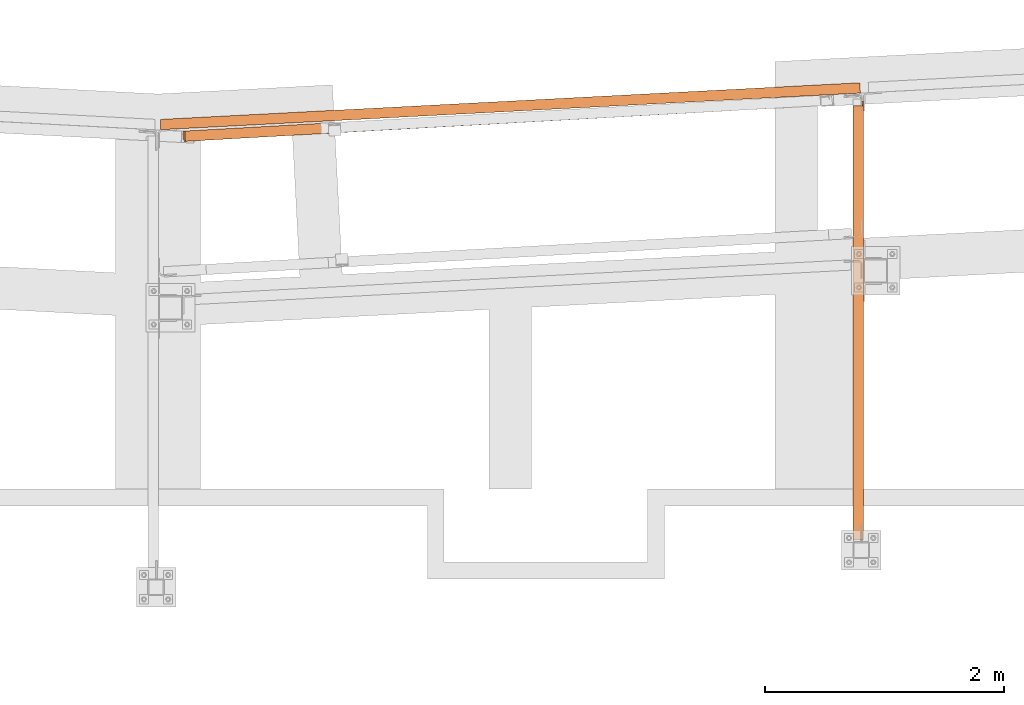
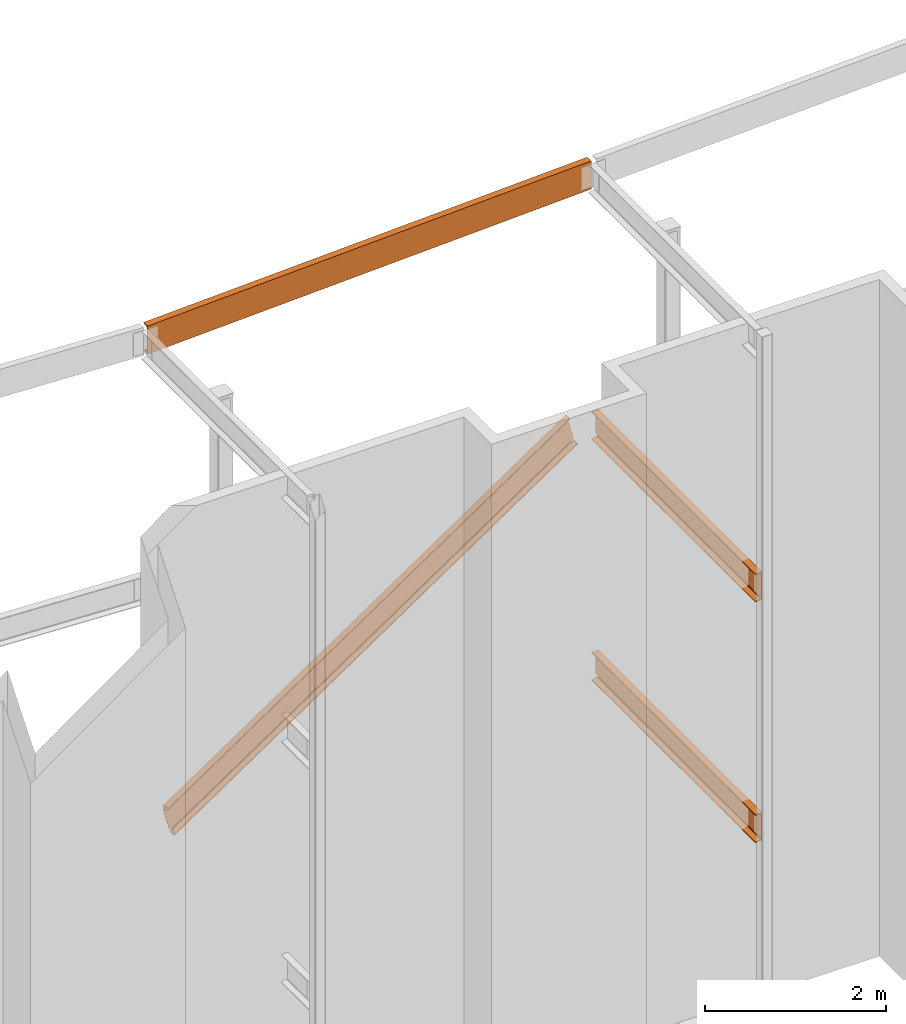
# One storey, part 16 of 89: 4 proxies.
"""IFC4 building model written with IfcOpenShell, lengths in feet."""

import ifcopenshell
import ifcopenshell.guid

model = None  # the IFC model being written
_history = None  # IfcOwnerHistory: only IFC2X3 demands one
_inside = {}  # id of a spatial element -> (the spatial element, [elements in it])
_under = {}  # id of a project, library or spatial element -> (it, [spatial elements below it])
_declared = {}  # id of a project -> (the project, [libraries it declares])
_typed = {}  # id of a type object -> (the type object, [elements of that type])
_made_of = {}  # id of a material, layer set ... -> (it, [elements and type objects made of it])


def new_model(schema):
    """Start an empty IFC model of exactly this schema.

    Asked for "IFC4X3", IfcOpenShell would pick the latest addendum, in which some entities
    have other attributes; the version numbers below select the first issue.
    IFC2X3 requires an IfcOwnerHistory on every rooted entity: one is made here for all.
    """
    global model, _history
    if schema == "IFC4X3":
        model = ifcopenshell.file(schema_version=(4, 3, 0, 0))
    else:
        model = ifcopenshell.file(schema=schema)
    _inside.clear()
    _under.clear()
    _declared.clear()
    _typed.clear()
    _made_of.clear()
    _history = None
    if model.schema == "IFC2X3":
        org = make("IfcOrganization", Name="unknown")
        user = make(
            "IfcPersonAndOrganization",
            ThePerson=make("IfcPerson", FamilyName="unknown"),
            TheOrganization=org,
        )
        app = make(
            "IfcApplication",
            ApplicationDeveloper=org,
            Version="unknown",
            ApplicationFullName="unknown",
            ApplicationIdentifier="unknown",
        )
        _history = make(
            "IfcOwnerHistory",
            OwningUser=user,
            OwningApplication=app,
            ChangeAction="ADDED",
            CreationDate=0,
        )
    return model


def make(cls, **values):
    """One entity of the class cls with the attributes given. An attribute that is None is left unset."""
    return model.create_entity(
        cls, **{name: value for name, value in values.items() if value is not None}
    )


def entity(cls, *values):
    """Any entity or typed value of the class cls, its attributes in the order of the schema. None: left unset."""
    e = model.create_entity(cls)
    for i, value in enumerate(values):
        if value is not None:
            e[i] = value
    return e


def rooted(cls, **values):
    """An entity with a GlobalId (a new one), such as an element, a storey or a relation."""
    return make(cls, GlobalId=ifcopenshell.guid.new(), OwnerHistory=_history, **values)


def si_unit(unit_type, name, prefix=None):
    """IfcSIUnit, for example si_unit("LENGTHUNIT", "METRE", prefix="MILLI")."""
    return make("IfcSIUnit", UnitType=unit_type, Prefix=prefix, Name=name)


def converted_unit(unit_type, name, factor, base, dimensions=None, offset=None):
    """IfcConversionBasedUnit, such as the inch: factor (a typed value) times the base unit."""
    return make(
        "IfcConversionBasedUnit"
        if offset is None
        else "IfcConversionBasedUnitWithOffset",
        ConversionOffset=offset,
        Dimensions=None
        if dimensions is None
        else entity("IfcDimensionalExponents", *dimensions),
        UnitType=unit_type,
        Name=name,
        ConversionFactor=make(
            "IfcMeasureWithUnit", ValueComponent=factor, UnitComponent=base
        ),
    )


def derived_unit(unit_type, elements):
    """IfcDerivedUnit: a product of units, each with its exponent."""
    return make(
        "IfcDerivedUnit",
        Elements=[
            make("IfcDerivedUnitElement", Unit=unit, Exponent=power)
            for unit, power in elements
        ],
        UnitType=unit_type,
    )


def assignment(units):
    """IfcUnitAssignment: the units of a project."""
    return None if units is None else make("IfcUnitAssignment", Units=units)


def point(xyz):
    """IfcCartesianPoint."""
    return None if xyz is None else make("IfcCartesianPoint", Coordinates=xyz)


def direction(xyz):
    """IfcDirection."""
    return None if xyz is None else make("IfcDirection", DirectionRatios=xyz)


def frame(location, z_axis=None, x_axis=None):
    """IfcAxis2Placement3D, a coordinate frame: its origin and axes. An axis left out is left unset."""
    return make(
        "IfcAxis2Placement3D",
        Location=point(location),
        Axis=direction(z_axis),
        RefDirection=direction(x_axis),
    )


def origin():
    """The frame at (0, 0, 0) with its axes left unset."""
    return frame((0.0, 0.0, 0.0))


def place(relative_to, where):
    """IfcLocalPlacement: puts the frame where relative to a parent placement (None: the world)."""
    return make(
        "IfcLocalPlacement", PlacementRelTo=relative_to, RelativePlacement=where
    )


def context(
    kind, dimensions, precision=None, world=None, true_north=None, identifier=None
):
    """IfcGeometricRepresentationContext, for example the 3D "Model" context."""
    return make(
        "IfcGeometricRepresentationContext",
        ContextIdentifier=identifier,
        ContextType=kind,
        CoordinateSpaceDimension=dimensions,
        Precision=precision,
        WorldCoordinateSystem=world,
        TrueNorth=true_north,
    )


def subcontext(parent, identifier, kind, view, scale=None):
    """IfcGeometricRepresentationSubContext, for example "Body" below "Model"."""
    return make(
        "IfcGeometricRepresentationSubContext",
        ContextIdentifier=identifier,
        ContextType=kind,
        ParentContext=parent,
        TargetScale=scale,
        TargetView=view,
    )


def project(units=None, contexts=None):
    """IfcProject with its units and contexts."""
    return rooted(
        "IfcProject",
        Name="project",
        RepresentationContexts=contexts,
        UnitsInContext=assignment(units),
    )


def spatial(cls, under=None, at=None, **own):
    """A site, building, storey or space (cls), placed at a placement, below another one or the project."""
    s = rooted(cls, ObjectPlacement=at, **own)
    if under is not None:
        _under.setdefault(under.id(), (under, []))[1].append(s)
    return s


def faces_of(points, faces, orient=None, outer=None):
    """IfcFace entities. A face is a list of loops; a loop is a list of indices into points, from 0.

    orient and outer hold one flag for each loop. By default every Orientation is true, the
    first loop of a face is its IfcFaceOuterBound and the others are IfcFaceBound.
    """
    made = []
    for i, loops in enumerate(faces):
        bounds = []
        for j, loop in enumerate(loops):
            is_outer = j == 0 if outer is None else outer[i][j]
            bounds.append(
                make(
                    "IfcFaceOuterBound" if is_outer else "IfcFaceBound",
                    Bound=make("IfcPolyLoop", Polygon=[points[k] for k in loop]),
                    Orientation=True if orient is None else orient[i][j],
                )
            )
        made.append(make("IfcFace", Bounds=bounds))
    return made


def face_set(faces, orient=None, outer=None):
    """The faces of one IfcConnectedFaceSet. surface_model builds it on its shared points."""
    return ("IfcConnectedFaceSet", faces, orient, outer)


def faceted_brep(points, faces, orient=None, outer=None, voids=None):
    """IfcFacetedBrep: a solid bounded by flat faces; with voids (closed shells), ...WithVoids."""
    shared = [point(p) for p in points]
    hull = make("IfcClosedShell", CfsFaces=faces_of(shared, faces, orient, outer))
    if voids is None:
        return make("IfcFacetedBrep", Outer=hull)
    return make(
        "IfcFacetedBrepWithVoids",
        Outer=hull,
        Voids=[
            make(cls, CfsFaces=faces_of(shared, fs, o, b)) for cls, fs, o, b in voids
        ],
    )


def surface_model(cls, points, shells):
    """IfcFaceBasedSurfaceModel or IfcShellBasedSurfaceModel (cls): surfaces that need not close."""
    shared = [point(p) for p in points]
    made = [make(c, CfsFaces=faces_of(shared, fs, o, b)) for c, fs, o, b in shells]
    if cls == "IfcFaceBasedSurfaceModel":
        return make(cls, FbsmFaces=made)
    return make(cls, SbsmBoundary=made)


def shape(context_of_items, identifier, shape_type, items):
    """IfcShapeRepresentation: the items that make up one representation, for example the "Body"."""
    return make(
        "IfcShapeRepresentation",
        ContextOfItems=context_of_items,
        RepresentationIdentifier=identifier,
        RepresentationType=shape_type,
        Items=items,
    )


def source(mapping_origin, context_of_items, identifier, shape_type, items):
    """IfcRepresentationMap: a shape defined once, which mapped items show again and again."""
    return make(
        "IfcRepresentationMap",
        MappingOrigin=mapping_origin,
        MappedRepresentation=shape(context_of_items, identifier, shape_type, items),
    )


def transform(
    local_origin,
    x_axis=None,
    y_axis=None,
    z_axis=None,
    scale=None,
    scale2=None,
    scale3=None,
    uniform=True,
):
    """IfcCartesianTransformationOperator3D, or its non-uniform kind. x_axis, y_axis, z_axis: its Axis1, 2, 3."""
    if uniform:
        return make(
            "IfcCartesianTransformationOperator3D",
            Axis1=direction(x_axis),
            Axis2=direction(y_axis),
            LocalOrigin=point(local_origin),
            Scale=scale,
            Axis3=direction(z_axis),
        )
    return make(
        "IfcCartesianTransformationOperator3DnonUniform",
        Axis1=direction(x_axis),
        Axis2=direction(y_axis),
        LocalOrigin=point(local_origin),
        Scale=scale,
        Axis3=direction(z_axis),
        Scale2=scale2,
        Scale3=scale3,
    )


def mapped(mapping_source, mapping_target):
    """IfcMappedItem: shows the shape of a source again, moved by a transform."""
    return make(
        "IfcMappedItem", MappingSource=mapping_source, MappingTarget=mapping_target
    )


def material(Name=None, Category=None):
    """IfcMaterial."""
    return make("IfcMaterial", Name=Name, Category=Category)


def constituent(of_material, Name=None, Category=None, fraction=None):
    """IfcMaterialConstituent: one of the materials an element consists of."""
    return make(
        "IfcMaterialConstituent",
        Name=Name,
        Material=of_material,
        Fraction=fraction,
        Category=Category,
    )


def constituent_set(constituents=None, Name=None):
    """IfcMaterialConstituentSet."""
    return make(
        "IfcMaterialConstituentSet", Name=Name, MaterialConstituents=constituents
    )


def made_of(thing, what):
    """Note that an element or type object is made of a material, layer set ...; save() writes the relation."""
    if what is not None:
        _made_of.setdefault(what.id(), (what, []))[1].append(thing)
    return thing


def type_object(cls, material=None, **own):
    """A type object (cls), such as IfcWallType, which elements share."""
    return made_of(rooted(cls, **own), material)


def type_shapes(of_type, sources):
    """Give a type object the sources (RepresentationMaps) that its elements show as mapped items."""
    of_type.RepresentationMaps = sources


def element(
    cls,
    number,
    at=None,
    inside=None,
    cuts=None,
    type_object=None,
    material=None,
    context=None,
    identifier="Body",
    shape_type=None,
    held_by="IfcProductDefinitionShape",
    body=None,
    shapes=None,
    **own,
):
    """One element of the class cls, such as IfcWall. Its Tag is "e" and its number.

    at: its placement. inside: the storey or other place that contains it. cuts: it is an
    opening in that element (IfcRelVoidsElement). A single representation is given by context,
    identifier, shape_type and body (its items); several are given by shapes. held_by: the class
    of the entity that holds the representations. save() writes the other relations.
    """
    e = rooted(cls, Tag="e%d" % number, ObjectPlacement=at, **own)
    if body is not None:
        shapes = [shape(context, identifier, shape_type, body)]
    if shapes is not None:
        e.Representation = make(held_by, Representations=shapes)
    if inside is not None:
        _inside.setdefault(inside.id(), (inside, []))[1].append(e)
    if cuts is not None:
        rooted(
            "IfcRelVoidsElement", RelatingBuildingElement=cuts, RelatedOpeningElement=e
        )
    if type_object is not None:
        _typed.setdefault(type_object.id(), (type_object, []))[1].append(e)
    return made_of(e, material)


def aggregate(whole, parts):
    """IfcRelAggregates: a whole, such as a stair, and the parts it consists of."""
    return rooted("IfcRelAggregates", RelatingObject=whole, RelatedObjects=parts)


def save(model, path):
    """Write the relations noted so far, then the file.

    IfcRelAggregates (storeys below a building ...), IfcRelContainedInSpatialStructure (elements
    in a storey), IfcRelDefinesByType, IfcRelAssociatesMaterial and IfcRelDeclares: one each for
    every whole, place, type object, material and project.
    """
    for whole, parts in _under.values():
        aggregate(whole, parts)
    for where, things in _inside.values():
        rooted(
            "IfcRelContainedInSpatialStructure",
            RelatedElements=things,
            RelatingStructure=where,
        )
    for kind, things in _typed.values():
        rooted("IfcRelDefinesByType", RelatedObjects=things, RelatingType=kind)
    for what, things in _made_of.values():
        rooted("IfcRelAssociatesMaterial", RelatedObjects=things, RelatingMaterial=what)
    for by, libraries in _declared.values():
        rooted("IfcRelDeclares", RelatingContext=by, RelatedDefinitions=libraries)
    model.write(path)


model = new_model("IFC4")

# Units and contexts
model_context = context("Model", 3, precision=0.0001, world=origin(), true_north=direction((6.12303176911189e-17, 1.0)))
body_context = subcontext(model_context, "Body", "Model", "MODEL_VIEW")
ifc_project = project(units=[converted_unit("LENGTHUNIT", "FOOT", entity("IfcRatioMeasure", 0.3048), si_unit("LENGTHUNIT", "METRE"), dimensions=[1, 0, 0, 0, 0, 0, 0]), converted_unit("AREAUNIT", "SQUARE FOOT", entity("IfcRatioMeasure", 0.09290304), si_unit("AREAUNIT", "SQUARE_METRE"), dimensions=[2, 0, 0, 0, 0, 0, 0]), converted_unit("VOLUMEUNIT", "CUBIC FOOT", entity("IfcRatioMeasure", 0.028316846592), si_unit("VOLUMEUNIT", "CUBIC_METRE"), dimensions=[3, 0, 0, 0, 0, 0, 0]), si_unit("PLANEANGLEUNIT", "RADIAN"), si_unit("MASSUNIT", "GRAM", prefix="KILO"), derived_unit("MASSDENSITYUNIT", [(si_unit("MASSUNIT", "GRAM", prefix="KILO"), 1), (si_unit("LENGTHUNIT", "METRE"), -3)]), derived_unit("MOMENTOFINERTIAUNIT", [(si_unit("LENGTHUNIT", "METRE"), 4)]), si_unit("TIMEUNIT", "SECOND"), si_unit("FREQUENCYUNIT", "HERTZ"), si_unit("THERMODYNAMICTEMPERATUREUNIT", "DEGREE_CELSIUS"), derived_unit("THERMALTRANSMITTANCEUNIT", [(si_unit("MASSUNIT", "GRAM", prefix="KILO"), 1), (si_unit("THERMODYNAMICTEMPERATUREUNIT", "KELVIN"), -1), (si_unit("TIMEUNIT", "SECOND"), -3)]), derived_unit("VOLUMETRICFLOWRATEUNIT", [(si_unit("LENGTHUNIT", "METRE"), 3), (si_unit("TIMEUNIT", "SECOND"), -1)]), si_unit("ELECTRICCURRENTUNIT", "AMPERE"), si_unit("ELECTRICVOLTAGEUNIT", "VOLT"), si_unit("POWERUNIT", "WATT"), si_unit("FORCEUNIT", "NEWTON"), si_unit("ILLUMINANCEUNIT", "LUX"), si_unit("LUMINOUSFLUXUNIT", "LUMEN"), si_unit("LUMINOUSINTENSITYUNIT", "CANDELA"), derived_unit("USERDEFINED", [(si_unit("MASSUNIT", "GRAM", prefix="KILO"), -1), (si_unit("LENGTHUNIT", "METRE"), -2), (si_unit("TIMEUNIT", "SECOND"), 3), (si_unit("LUMINOUSFLUXUNIT", "LUMEN"), 1)]), derived_unit("LINEARVELOCITYUNIT", [(si_unit("LENGTHUNIT", "METRE"), 1), (si_unit("TIMEUNIT", "SECOND"), -1)]), si_unit("PRESSUREUNIT", "PASCAL"), derived_unit("USERDEFINED", [(si_unit("LENGTHUNIT", "METRE"), -2), (si_unit("MASSUNIT", "GRAM", prefix="KILO"), 1), (si_unit("TIMEUNIT", "SECOND"), -2)]), derived_unit("LINEARFORCEUNIT", [(si_unit("MASSUNIT", "GRAM", prefix="KILO"), 1), (si_unit("LENGTHUNIT", "METRE"), 1), (si_unit("TIMEUNIT", "SECOND"), -2), (si_unit("LENGTHUNIT", "METRE"), -1)]), derived_unit("PLANARFORCEUNIT", [(si_unit("MASSUNIT", "GRAM", prefix="KILO"), 1), (si_unit("LENGTHUNIT", "METRE"), 1), (si_unit("TIMEUNIT", "SECOND"), -2), (si_unit("LENGTHUNIT", "METRE"), -2)])], contexts=[model_context])

# Site, building, storey
site_placement = place(None, origin())
site = spatial("IfcSite", under=ifc_project, at=site_placement, CompositionType="ELEMENT")
building_placement = place(site_placement, frame((-472.238160486, -49.138065117, 0.0)))
building = spatial("IfcBuilding", under=site, at=building_placement, CompositionType="ELEMENT")
storey_placement = place(building_placement, origin())
storey = spatial("IfcBuildingStorey", under=building, at=storey_placement, Name="Level 1", CompositionType="ELEMENT", Elevation=0.0)

# Proxies
ifc_material_1 = material(Name="Color 7720", Category="Materials")
ifc_material_2 = material()
ifc_constituent_1 = constituent(ifc_material_2)
ifc_constituent_2 = constituent(ifc_material_1, Name="Color 7720", Category="Materials")
ifc_constituent_set_1 = constituent_set(constituents=[ifc_constituent_1, ifc_constituent_2])
building_element_proxy_type_1 = type_object("IfcBuildingElementProxyType", Name="33B1", PredefinedType="NOTDEFINED", material=ifc_constituent_set_1)
shared_shape_1 = source(origin(), body_context, "Body", "Brep", [
    faceted_brep([(1.07356754597276e-08, 0.098822714376638, 0.0), (0.00517908973890258, 0.0, 0.0), (0.00517908973890258, 0.0, 1.25), (1.07356754597276e-08, 0.098822714376638, 1.25), (1.07356754597276e-08, 0.098822714376638, 1.18593784317541), (0.00112219925708246, 0.0774100818106263, 1.18236429742144), (0.00203400554855193, 0.060011781330104, 1.17618476966831), (0.00277876240696173, 0.0458009739160161, 1.16438573990163), (0.00326544140554574, 0.0365145854208322, 1.14840935276805), (0.00343455786415348, 0.0332876511583891, 1.13020833333333), (0.00343455786415348, 0.0332876511583891, 0.119791666666668), (0.00326544140554574, 0.0365145854208322, 0.101590647231948), (0.00277876240696173, 0.0458009739160161, 0.0856142600983674), (0.00203400554855193, 0.060011781330104, 0.0738152303316859), (0.00112219925708246, 0.0774100818106263, 0.0676357025785457), (1.07356754597276e-08, 0.098822714376638, 0.0640621568245869), (19.1876777550914, 1.00531215615104, 1.25), (19.1876777550914, 1.00531215615104, 0.0), (19.1728492341558, 1.28825719099814, 0.0), (19.1728492341558, 1.28825719099814, 0.0333340558078774), (19.1836208646095, 1.08272223796166, 0.0676357025785457), (19.184532670901, 1.06532393748114, 0.0738152303316859), (19.1852774277594, 1.05111313006694, 0.0856142600983674), (19.185764106758, 1.04182674157175, 0.101590647231948), (19.1859332232166, 1.03859980730942, 0.119791666666668), (19.1859332232166, 1.03859980730942, 1.13020833333333), (19.185764106758, 1.04182674157175, 1.14840935276805), (19.1852774277594, 1.05111313006694, 1.16438573990163), (19.184532670901, 1.06532393748114, 1.17618476966831), (19.1836208646095, 1.08272223796166, 1.18236429742144), (19.1728492341558, 1.28825719099814, 1.21666594419212), (19.1728492341558, 1.28825719099814, 1.25), (0.0, 0.283450740107469, 1.25), (0.0, 0.283450740107469, 1.21666594419212), (0.0, 0.283450740107469, 0.0333340558077744), (0.0, 0.283450740107469, 0.0)], [[[0, 1, 2, 3, 4, 5, 6, 7, 8, 9, 10, 11, 12, 13, 14, 15]], [[16, 17, 18, 19, 20, 21, 22, 23, 24, 25, 26, 27, 28, 29, 30, 31]], [[32, 31, 30, 33]], [[33, 30, 29, 5, 4]], [[28, 6, 5, 29]], [[27, 7, 6, 28]], [[26, 8, 7, 27]], [[25, 9, 8, 26]], [[24, 10, 9, 25]], [[23, 11, 10, 24]], [[22, 12, 11, 23]], [[21, 13, 12, 22]], [[20, 14, 13, 21]], [[15, 14, 20, 19, 34]], [[34, 19, 18, 35]], [[35, 18, 17, 1, 0]], [[16, 2, 1, 17]], [[3, 2, 16, 31, 32]], [[32, 33, 4, 3]], [[35, 0, 15, 34]]]),
])
type_shapes(building_element_proxy_type_1, [shared_shape_1])
proxy_1_placement = place(building_placement, frame((230.562436454417, 1017.85373831147, 29.8333333333333)))
element("IfcBuildingElementProxy", 1, at=proxy_1_placement, inside=storey, type_object=building_element_proxy_type_1, material=ifc_material_1, Name="33B1:33B1", ObjectType="33B1:33B1", PredefinedType="NOTDEFINED", context=body_context, shape_type="MappedRepresentation", body=[
    mapped(shared_shape_1, transform((0.0, 0.0, 0.0), scale=1.0)),
])
ifc_constituent_3 = constituent(ifc_material_2)
ifc_constituent_4 = constituent(ifc_material_1, Name="Color 7720", Category="Materials")
ifc_constituent_set_2 = constituent_set(constituents=[ifc_constituent_3, ifc_constituent_4])
building_element_proxy_type_2 = type_object("IfcBuildingElementProxyType", Name="34B1", PredefinedType="NOTDEFINED", material=ifc_constituent_set_2)
shared_shape_2 = source(origin(), body_context, "Body", "SurfaceModel", [
    surface_model("IfcFaceBasedSurfaceModel", [(0.303696853038161, 0.299216112058275, 0.0100472176130761), (0.306442138279095, 0.299370292556091, 0.0), (0.322329646931337, 0.0164827444974662, 0.0), (0.319584361690403, 0.0163285639996502, 0.0100472176130761), (0.272073491763877, 0.264054221976608, 0.132623272492586), (0.00186911866509831, 0.248879024818052, 1.12151947025676), (0.0, 0.282159912824909, 1.12151947025676), (0.27020437309892, 0.297335109983464, 0.132623272492586), (17.4853650013783, 1.26417163321889, 11.8555669009117), (17.4726841039552, 1.263459449636, 11.901976554102), (17.4885716126074, 0.980571901577378, 11.901976554102), (17.4955203771162, 0.980962157553677, 11.8765454083247), (17.4942175429467, 1.10654630421539, 11.8555669009117), (17.776936677922, 1.28054685922518, 10.7884704694103), (17.5067323048232, 1.26537166206663, 11.7773666671744), (17.5086014234882, 1.23209077405977, 11.7773666671744), (17.778805796587, 1.24726597121833, 10.7884704694103), (17.8263166665136, 0.999540313241368, 10.6658944145308), (17.8290619517545, 0.999694493739185, 10.6558471969177), (17.8131744431022, 1.28258204179781, 10.6558471969177), (17.8104291578614, 1.28242786129999, 10.6658944145308), (17.6723666156622, 1.27467400345142, 10.7309934061653), (17.474895242037, 1.26358363139866, 11.7521389479438), (17.459821718768, 1.26273707334758, 11.7445609823409), (17.4429832387451, 1.26179139193152, 11.7435994189647), (17.4271474337542, 1.26090202267312, 11.749412303753), (17.4149171323874, 1.26021514543129, 11.7610442105221), (17.4083025499831, 1.25984365776446, 11.7765832781736), (17.4083908825644, 1.2598486186921, 11.7934754509082), (17.4151676114774, 1.26022921281856, 11.8089442718168), (17.4275188897288, 1.26092288435495, 11.8204472311014), (17.464769696828, 1.26301496130975, 11.906505391597), (0.0468476088837519, 0.284790964623994, 1.30471443339433), (0.00187177189698673, 0.282265035136675, 1.22557497871247), (0.00461705713792071, 0.282419215634604, 1.2155277610994), (0.0629075018788114, 0.285692919095595, 1.25110496611269), (0.0783833740528621, 0.28656207383483, 1.25672973424961), (0.0948259067738491, 0.28748551808917, 1.25590122080313), (0.10965999990276, 0.28831862928314, 1.24874918103221), (0.12056245445757, 0.288930932094786, 1.23639371114838), (0.125825813763782, 0.289226532474117, 1.22076982765763), (0.124625771888049, 0.289159135814884, 1.20432442029601), (0.117150269949519, 0.288739297251709, 1.18963303940614), (0.104570062260109, 0.288032768597873, 1.17899653350172), (0.302041435885315, 0.299123140650636, 0.157850991723214), (0.317109281134407, 0.299969379813206, 0.165427437479559), (0.333941811413098, 0.300914727080226, 0.166392245455572), (0.349774260727429, 0.301803907877343, 0.160586944628864), (0.362006127742148, 0.30249087304901, 0.148965063556631), (0.368628311662121, 0.302862787631511, 0.133435512013145), (0.368553109771113, 0.302858564148664, 0.116549039962802), (0.361792874081857, 0.30247889631346, 0.10107927340897), (0.349457982501775, 0.301786145083952, 0.0895671425501767), (0.34867269002487, 0.301742041548437, 0.0891866722949395), (17.7665947779691, 1.27996603823419, 10.6909776304976), (17.7140338862532, 1.27701411748819, 10.6588878488301), (17.6985580769897, 1.27614496628212, 10.6532609229392), (17.6821147802179, 1.27522147911725, 10.6540876961211), (17.6672794271848, 1.27438829716459, 10.6612386750317), (17.6563756049599, 1.27377591754191, 10.6735938376469), (17.6511111246262, 1.27348025420349, 10.6892180567048), (17.6523105353809, 1.27354761541778, 10.705664189), (17.6597859795225, 1.27396745073497, 10.7203563591718), (17.8032083479337, 0.998242505635517, 10.679117618486), (0.343294426074522, 0.0176601668063086, 0.0517674321002595), (17.7229121871204, 1.11893012726944, 10.6588878488252), (17.7754450538782, 1.12238105083907, 10.6909776304927), (0.35752296592841, 0.144157054144671, 0.0891866722998671), (0.358336296157603, 0.143701927047346, 0.0895671425550901), (0.369519878000062, 0.164894505900747, 0.101079273413857), (0.373015288666721, 0.223406532036734, 0.116549039967648), (0.372901520314599, 0.225464310771144, 0.116952059026719), (17.6854225827148, 1.19776878319919, 10.6545884278252), (17.6867871674784, 1.19202654882383, 10.6540876961162), (17.706345873092, 1.13747813112627, 10.6532609229344), (17.6778158029995, 1.2147912033397, 10.6577841699171), (0.371956887407862, 0.242860889888789, 0.124202859305775), (17.6664119819453, 1.22840347705926, 10.6651356381964), (0.369642943040276, 0.256983668561588, 0.137087075520316), (0.371465868682861, 0.252338217314104, 0.133435512013126), (17.6701973721288, 1.22243236696454, 10.6612386750317), (17.6568340082527, 1.23717934620981, 10.6783183953159), (0.361660843404138, 0.265849165067721, 0.151241195530037), (0.364160594214155, 0.264129179532006, 0.148965063556741), (17.6585847174705, 1.23444121534328, 10.673593837647), (17.6536032510574, 1.24023435551442, 10.6977606415586), (0.345526940138512, 0.26817950887812, 0.162829665837245), (0.351694131266271, 0.267619349353708, 0.16058694462885), (17.6530496923214, 1.23896278050506, 10.6892180567048), (17.6616550981883, 1.2406865627122, 10.7203563591718), (17.6742357343281, 1.24139311542854, 10.7309934061653), (17.4767643607029, 1.23030274337407, 11.7521389479438), (17.461690837434, 1.2294561853231, 11.7445609823409), (17.444852357411, 1.22851050390693, 11.7435994189647), (17.4351493635061, 1.22796556511173, 11.7471611189038), (0.127071721903349, 0.255910643782499, 1.21222933323467), (0.126494890552067, 0.255878247824626, 1.204324420296), (0.119019388613566, 0.25545840926145, 1.18963303940614), (0.106439180924127, 0.254751880607614, 1.17899653350172), (0.303910554549248, 0.265842252662083, 0.15785099172321), (0.31897839979834, 0.266688491824539, 0.165427437479559), (0.335810930077031, 0.267633839091673, 0.166392245455572), (17.6541796540468, 1.24026672739501, 10.705664189), (17.4193792282523, 1.22384342917269, 11.7587504291711), (0.124203520126315, 0.252513105195362, 1.23167168136501), (0.127764362625328, 0.254709394121505, 1.2207698276576), (17.4290674610728, 1.22671467258158, 11.749412303753), (17.4124401894706, 1.21413993284148, 11.7729046647747), (0.115668448404932, 0.242719972585292, 1.24485445737068), (0.122771476830565, 0.249597834855422, 1.23639371114834), (17.4170723659125, 1.22183979403121, 11.761044210522), (17.4117203746049, 1.19984677241666, 11.7857878105003), (0.105860303265956, 0.227916394056706, 1.25220579641868), (0.112577727722737, 0.236366565120647, 1.24874918103216), (17.4111419789566, 1.20928575609696, 11.7765832781736), (17.4127352319496, 1.18245413723957, 11.7930420456905), (0.100208054015525, 0.210149321353356, 1.25540195452815), (17.4229001107598, 1.12254696500793, 11.8089442726355), (17.4363971939271, 1.10283882588601, 11.820447231921), (0.0288435353498926, 0.0, 1.245078825062), (0.0140912986742592, 0.0646883261517814, 1.22557497800434), (0.0134673334813158, 0.124834228118289, 1.2155277603921), (0.0717858055651845, 0.127608886234952, 1.25110496541047), (0.0861705415598237, 0.147906438773248, 1.25672973354897), (0.0994972987859342, 0.204308316367928, 1.25590122010445), (17.4128617151492, 1.18024249312896, 11.7934754517269), (17.4806572054801, 0.980127413254763, 11.906505391597), (0.0627351175361639, 0.00190341656264081, 1.30471443339432)], [face_set([[[0, 1, 2, 3]], [[4, 5, 6, 7]], [[8, 9, 10, 11, 12]], [[13, 14, 15, 16]], [[17, 18, 19, 20]], [[21, 13, 14, 22, 23, 24, 25, 26, 27, 28, 29, 30, 8, 9, 31, 32, 33, 34, 35, 36, 37, 38, 39, 40, 41, 42, 43, 6, 7, 44, 45, 46, 47, 48, 49, 50, 51, 52, 53, 0, 1, 19, 20, 54, 55, 56, 57, 58, 59, 60, 61, 62]], [[18, 2, 1, 19]], [[17, 63, 64, 3, 2, 18]], [[65, 66, 63, 64, 67, 68, 69, 70, 71, 72, 73, 74]], [[75, 76, 71, 72]], [[77, 78, 79, 76, 75, 80]], [[81, 82, 83, 78, 77, 84]], [[85, 86, 87, 82, 81, 88]], [[89, 90, 16, 15, 91, 92, 93, 94, 95, 96, 97, 98, 5, 4, 99, 100, 101, 86, 85, 102]], [[103, 104, 105, 95, 94, 106]], [[107, 108, 109, 104, 103, 110]], [[111, 112, 113, 108, 107, 114]], [[115, 116, 112, 111]], [[117, 118, 12, 11, 119, 120, 121, 122, 123, 124, 116, 115, 125]], [[126, 127, 119, 11, 10]], [[31, 32, 127, 126]], [[98, 43, 6, 5]], [[97, 42, 43, 98]], [[96, 41, 42, 97]], [[105, 40, 41, 96, 95]], [[109, 39, 40, 105, 104]], [[113, 38, 39, 109, 108]], [[116, 124, 37, 38, 113, 112]], [[123, 36, 37, 124]], [[36, 123, 122, 35]], [[35, 122, 121, 34]], [[120, 33, 34, 121]], [[127, 32, 33, 120, 119]], [[64, 67, 53, 0, 3]], [[68, 52, 53, 67]], [[69, 51, 52, 68]], [[70, 50, 51, 69]], [[76, 79, 49, 50, 70, 71]], [[83, 48, 49, 79, 78]], [[87, 47, 48, 83, 82]], [[101, 46, 47, 87, 86]], [[46, 101, 100, 45]], [[45, 100, 99, 44]], [[44, 99, 4, 7]], [[31, 126, 10, 9]], [[118, 30, 8, 12]], [[117, 29, 30, 118]], [[125, 28, 29, 117]], [[111, 114, 27, 28, 125, 115]], [[110, 26, 27, 114, 107]], [[106, 25, 26, 110, 103]], [[93, 24, 25, 106, 94]], [[24, 93, 92, 23]], [[23, 92, 91, 22]], [[22, 91, 15, 14]], [[16, 90, 21, 13]], [[89, 62, 21, 90]], [[102, 61, 62, 89]], [[88, 60, 61, 102, 85]], [[84, 59, 60, 88, 81]], [[80, 58, 59, 84, 77]], [[72, 73, 57, 58, 80, 75]], [[74, 56, 57, 73]], [[56, 74, 65, 55]], [[55, 65, 66, 54]], [[54, 66, 63, 17, 20]]])]),
])
type_shapes(building_element_proxy_type_2, [shared_shape_2])
proxy_2_placement = place(building_placement, frame((231.178396575528, 1017.5331409589, 8.35002392391732)))
element("IfcBuildingElementProxy", 2, at=proxy_2_placement, inside=storey, type_object=building_element_proxy_type_2, material=ifc_material_1, Name="34B1:34B1", ObjectType="34B1:34B1", PredefinedType="NOTDEFINED", context=body_context, shape_type="MappedRepresentation", body=[
    mapped(shared_shape_2, transform((0.0, 0.0, 0.0), scale=1.0)),
])
ifc_constituent_5 = constituent(ifc_material_2)
ifc_constituent_6 = constituent(ifc_material_1, Name="Color 7720", Category="Materials")
ifc_constituent_set_3 = constituent_set(constituents=[ifc_constituent_5, ifc_constituent_6])
building_element_proxy_type_3 = type_object("IfcBuildingElementProxyType", Name="c740", PredefinedType="NOTDEFINED", material=ifc_constituent_set_3)
shared_shape_3 = source(origin(), body_context, "Body", "Brep", [
    faceted_brep([(0.0, 0.0, 1.25), (0.0, 0.0, 1.21666594419212), (0.205817018106757, 0.0, 1.18236429742145), (0.223239195075223, 0.0, 1.17618476966831), (0.237469504634021, 0.0, 1.16438573990163), (0.24676863726728, 0.0, 1.14840935276805), (0.25, 0.0, 1.13020833333333), (0.25, 0.0, 0.11979166666667), (0.24676863726728, 0.0, 0.10159064723195), (0.237469504634021, 0.0, 0.0856142600983691), (0.223239195075223, 0.0, 0.0738152303316895), (0.205817018106757, 0.0, 0.0676357025785492), (0.0, 0.0, 0.0333340558078792), (0.0, 0.0, 0.0), (0.283333333333331, 0.0, 0.0), (0.283333333333331, 0.0, 1.25), (0.25, 12.0386783691669, 0.125), (0.25, 12.0386783691669, 1.125), (0.283333333333331, 12.0386783691669, 1.125), (0.283333333333331, 12.0386783691669, 0.125), (0.0, 11.8831823622785, 1.21666594419212), (0.0, 11.8831823622785, 1.25), (0.184374999999989, 11.8928450358334, 1.18593784317542), (0.205817018106757, 11.8928450358334, 1.18236429742146), (0.223239195075223, 11.8928450358334, 1.17618476966831), (0.237469504634021, 11.8932987403761, 1.16438573990163), (0.234718575567058, 11.8928450358334, 1.16666666666665), (0.24676863726728, 11.8975616651703, 1.14840935276805), (0.24542282713287, 11.8960167219789, 1.15072152365144), (0.250000000000028, 11.9155185015668, 1.13020833333333), (0.248758027692986, 11.9050489199507, 1.13720388411723), (0.250000000000057, 11.9185665594848, 0.121828313854641), (0.250000000000057, 11.9155185015668, 0.11979166666667), (0.250000000000057, 11.9185665594848, 1.12817168614536), (0.250000000000057, 11.9345117025001, 1.125), (0.250000000000057, 11.9345117025001, 0.125), (0.246768637267309, 11.8975616651703, 0.101590647231948), (0.248758027692986, 11.9050489199507, 0.112796115882768), (0.237469504634021, 11.8932987403761, 0.0856142600983745), (0.24542282713287, 11.8960167219789, 0.0992784763485588), (0.223239195075223, 11.8928450358334, 0.0738152303316895), (0.234718575567058, 11.8928450358334, 0.0833333333333517), (0.205817018106757, 11.8928450358334, 0.0676357025785492), (0.0, 11.8831823622785, 0.0333340558078827), (0.184374999999989, 11.8928450358334, 0.0640621568245887), (0.0, 11.8831823622785, 0.0), (0.184374999999989, 11.8928450358334, 0.0), (0.283333333333331, 11.8928450358334, 0.0), (0.28333333333336, 11.8960167219789, 0.0992784763485499), (0.28333333333336, 11.9050489199507, 0.11279611588277), (0.28333333333336, 11.9185665594848, 0.121828313854641), (0.28333333333336, 11.9345117025001, 0.125), (0.28333333333336, 11.9345117025001, 1.125), (0.28333333333336, 11.9185665594848, 1.12817168614536), (0.28333333333336, 11.9050489199507, 1.13720388411723), (0.28333333333336, 11.8960167219789, 1.15072152365145), (0.28333333333336, 11.8928450358334, 1.16666666666667), (0.28333333333336, 11.8928450358334, 1.25), (0.28333333333336, 11.8928450358334, 0.0833333333333304), (0.184374999999989, 11.8928450358334, 1.25)], [[[0, 1, 2, 3, 4, 5, 6, 7, 8, 9, 10, 11, 12, 13, 14, 15]], [[16, 17, 18, 19]], [[20, 1, 0, 21]], [[22, 23, 2, 1, 20]], [[24, 3, 2, 23]], [[25, 4, 3, 24, 26]], [[27, 5, 4, 25, 28]], [[29, 6, 5, 27, 30]], [[31, 32, 7, 6, 29, 33, 34, 17, 16, 35]], [[36, 8, 7, 32, 37]], [[38, 9, 8, 36, 39]], [[40, 10, 9, 38, 41]], [[42, 11, 10, 40]], [[43, 12, 11, 42, 44]], [[45, 13, 12, 43]], [[46, 47, 14, 13, 45]], [[48, 49, 50, 51, 19, 18, 52, 53, 54, 55, 56, 57, 15, 14, 47, 58]], [[21, 0, 15, 57, 59]], [[59, 57, 56, 26, 24, 23, 22]], [[26, 56, 55, 28, 25]], [[28, 55, 54, 30, 27]], [[30, 54, 53, 33, 29]], [[33, 53, 52, 34]], [[17, 34, 52, 18]], [[59, 22, 20, 21]], [[19, 51, 35, 16]], [[50, 31, 35, 51]], [[31, 50, 49, 37, 32]], [[37, 49, 48, 39, 36]], [[39, 48, 58, 41, 38]], [[44, 46, 47, 58, 41, 40, 42]], [[45, 43, 44, 46]]]),
])
type_shapes(building_element_proxy_type_3, [shared_shape_3])
proxy_3_placement = place(building_placement, frame((249.55, 1006.59895833333, 8.35416666666667)))
element("IfcBuildingElementProxy", 3, at=proxy_3_placement, inside=storey, type_object=building_element_proxy_type_3, material=ifc_material_1, Name="c740:c740", ObjectType="c740:c740", PredefinedType="NOTDEFINED", context=body_context, shape_type="MappedRepresentation", body=[
    mapped(shared_shape_3, transform((0.0, 0.0, 0.0), scale=1.0)),
])
ifc_constituent_7 = constituent(ifc_material_2)
ifc_constituent_8 = constituent(ifc_material_1, Name="Color 7720", Category="Materials")
ifc_constituent_set_4 = constituent_set(constituents=[ifc_constituent_7, ifc_constituent_8])
building_element_proxy_type_4 = type_object("IfcBuildingElementProxyType", Name="c761", PredefinedType="NOTDEFINED", material=ifc_constituent_set_4)
shared_shape_4 = source(origin(), body_context, "Body", "Brep", [
    faceted_brep([(0.0, 0.0, 1.25), (0.0, 0.0, 1.21666594419212), (0.205817018106728, 0.0, 1.18236429742144), (0.223239195075223, 0.0, 1.17618476966831), (0.237469504634021, 0.0, 1.16438573990163), (0.24676863726728, 0.0, 1.14840935276805), (0.249999999999972, 0.0, 1.13020833333333), (0.249999999999972, 0.0, 0.119791666666668), (0.24676863726728, 0.0, 0.101590647231948), (0.237469504634021, 0.0, 0.0856142600983674), (0.223239195075223, 0.0, 0.0738152303316859), (0.205817018106728, 0.0, 0.0676357025785457), (0.0, 0.0, 0.0333340558078774), (0.0, 0.0, 0.0), (0.283333333333331, 0.0, 0.0), (0.283333333333331, 0.0, 1.25), (0.249999999999972, 12.0388702382777, 1.13020833333333), (0.283333333333331, 12.0388702382777, 1.13020833333333), (0.283333333333331, 12.0388702382777, 0.119791666666668), (0.249999999999972, 12.0388702382777, 0.119791666666668), (0.0, 11.9138702382777, 1.21666594419212), (0.0, 11.9138702382777, 1.25), (0.205817018106728, 11.9138702382777, 1.18236429742144), (0.208249999999993, 11.9138702382777, 1.18150133528077), (0.223239195075251, 11.9138702382777, 1.17618476966832), (0.228437025551159, 11.9138702382777, 1.17187500000002), (0.237469504634021, 11.9153599447338, 1.16438573990169), (0.242391291776357, 11.9170419244231, 1.15592985698479), (0.24676863726728, 11.922066964687, 1.14840935276805), (0.25, 11.9555369049443, 1.13020833333333), (0.247833353429883, 11.926074122395, 1.14241221745056), (0.249436906902559, 11.9395917619291, 1.1333800194787), (0.25, 11.9555369049443, 0.119791666666668), (0.247833353429883, 11.926074122395, 0.107587782549437), (0.24676863726728, 11.922066964687, 0.101590647231948), (0.249436906902559, 11.9395917619291, 0.116619980521293), (0.242391291776357, 11.9170419244231, 0.0940701430151947), (0.237469504634021, 11.9153599447338, 0.0856142600983425), (0.228437025551102, 11.9138702382777, 0.0781250000000071), (0.223239195075223, 11.9138702382777, 0.0738152303317037), (0.205817018106728, 11.9138702382777, 0.0676357025785492), (0.208249999999993, 11.9138702382777, 0.0684986647192467), (0.0, 11.9138702382777, 0.0333340558078739), (0.0, 11.9138702382777, 0.0), (0.208249999999993, 11.9138702382777, 0.0), (0.283333333333331, 11.9138702382777, 0.0), (0.28333333333336, 11.9170419244232, 0.0940701430152053), (0.28333333333336, 11.926074122395, 0.107587782549437), (0.28333333333336, 11.9395917619291, 0.116619980521296), (0.28333333333336, 11.9555369049443, 0.119791666666668), (0.28333333333336, 11.9555369049443, 1.13020833333333), (0.28333333333336, 11.9395917619291, 1.13338001947869), (0.28333333333336, 11.926074122395, 1.14241221745056), (0.28333333333336, 11.9170419244232, 1.15592985698478), (0.28333333333336, 11.9138702382777, 1.171875), (0.28333333333336, 11.9138702382777, 1.25), (0.28333333333336, 11.9138702382777, 0.0781249999999964), (0.208249999999993, 11.9138702382777, 1.25)], [[[0, 1, 2, 3, 4, 5, 6, 7, 8, 9, 10, 11, 12, 13, 14, 15]], [[16, 17, 18, 19]], [[20, 1, 0, 21]], [[22, 2, 1, 20]], [[23, 24, 3, 2, 22]], [[4, 3, 24, 25, 26]], [[5, 4, 26, 27, 28]], [[29, 6, 5, 28, 30, 31]], [[32, 7, 6, 29, 16, 19]], [[33, 34, 8, 7, 32, 35]], [[9, 8, 34, 36, 37]], [[10, 9, 37, 38, 39]], [[40, 11, 10, 39, 41]], [[42, 12, 11, 40]], [[43, 13, 12, 42]], [[44, 45, 14, 13, 43]], [[46, 47, 48, 49, 18, 17, 50, 51, 52, 53, 54, 55, 15, 14, 45, 56]], [[21, 0, 15, 55, 57]], [[55, 54, 25, 24, 23, 22, 20, 21, 57]], [[54, 53, 27, 26, 25]], [[53, 52, 30, 28, 27]], [[52, 51, 31, 30]], [[51, 50, 29, 31]], [[29, 50, 17, 16]], [[49, 32, 19, 18]], [[35, 32, 49, 48]], [[33, 35, 48, 47]], [[47, 46, 36, 34, 33]], [[46, 56, 38, 37, 36]], [[42, 43, 44, 45, 56, 38, 39, 41, 40]]]),
])
type_shapes(building_element_proxy_type_4, [shared_shape_4])
proxy_4_placement = place(building_placement, frame((249.55, 1006.59895833333, 19.0208333333333)))
element("IfcBuildingElementProxy", 4, at=proxy_4_placement, inside=storey, type_object=building_element_proxy_type_4, material=ifc_material_1, Name="c761:c761", ObjectType="c761:c761", PredefinedType="NOTDEFINED", context=body_context, shape_type="MappedRepresentation", body=[
    mapped(shared_shape_4, transform((0.0, 0.0, 0.0), scale=1.0)),
])

save(model, "model.ifc")
